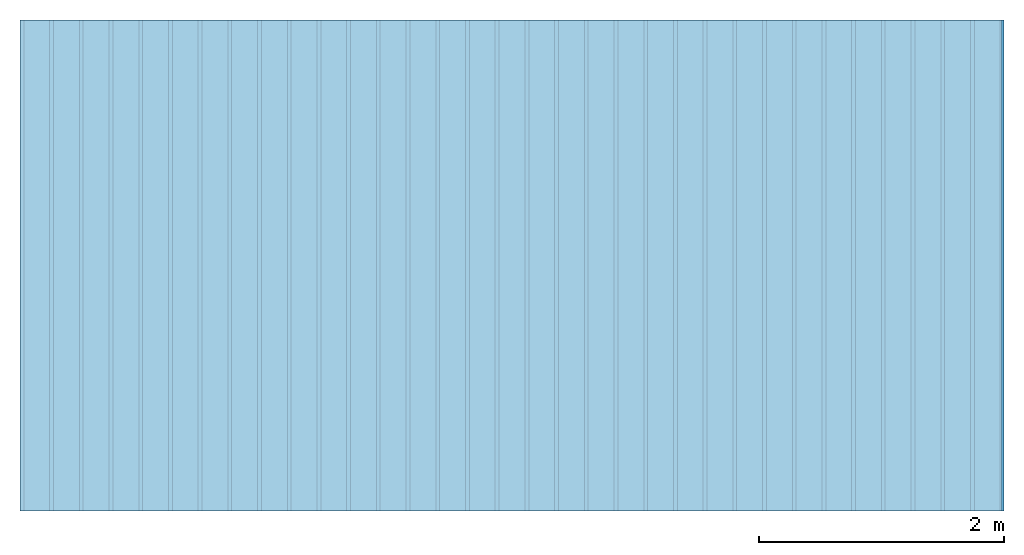
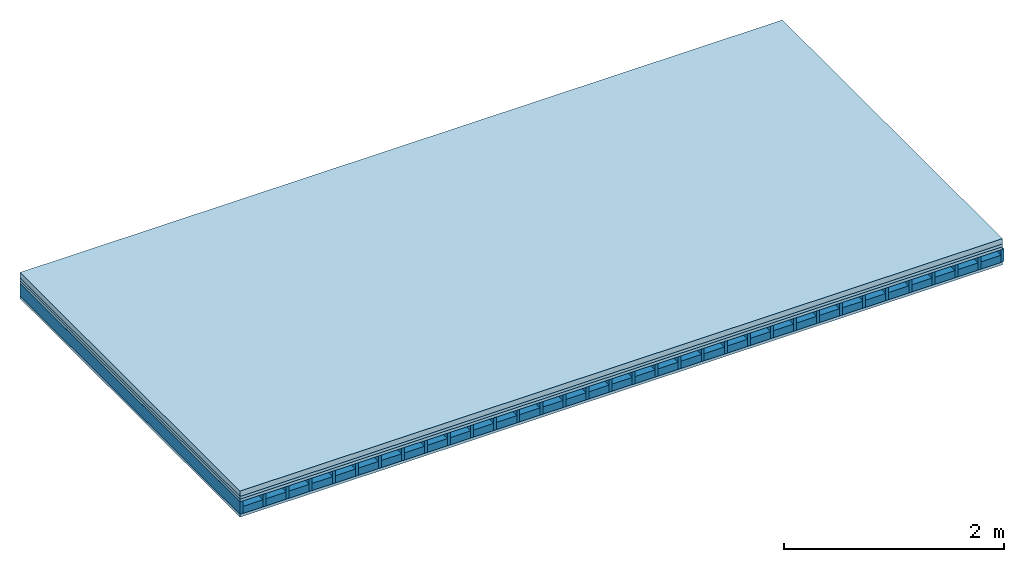
# One storey: 4 plates, 2 members, 1 element without a shape of its own.
"""IFC4 building model written with IfcOpenShell, lengths in metres."""

from ifc_helpers import new_model, si_unit, derived_unit, direction, frame, frame_2d, origin, origin_with_axes, place, context, project, spatial, rectangle, extrude, material, layer, layer_set, type_object, element, aggregate, save


model = new_model("IFC4")

# Units and contexts
plan_context = context("Plan", 3, precision=1e-05, world=origin(), true_north=direction((0.0, 1.0)))
model_context = context("Model", 3, precision=1e-05, world=origin(), true_north=direction((0.0, 1.0)))
ifc_project = project(units=[si_unit("LENGTHUNIT", "METRE"), derived_unit("SOUNDPRESSUREUNIT", [(si_unit("PRESSUREUNIT", "PASCAL", prefix="MICRO"), 0)]), si_unit("ENERGYUNIT", "JOULE", prefix="MEGA"), si_unit("MASSUNIT", "GRAM", prefix="KILO"), derived_unit("THERMALTRANSMITTANCEUNIT", [(si_unit("POWERUNIT", "WATT"), 1), (si_unit("AREAUNIT", "SQUARE_METRE"), -1), (si_unit("THERMODYNAMICTEMPERATUREUNIT", "KELVIN"), -1)]), derived_unit("AREADENSITYUNIT", [(si_unit("MASSUNIT", "GRAM", prefix="KILO"), 1), (si_unit("AREAUNIT", "SQUARE_METRE"), -1)]), derived_unit("USERDEFINED", [(si_unit("ENERGYUNIT", "JOULE", prefix="MEGA"), 1), (si_unit("AREAUNIT", "SQUARE_METRE"), -1)])], contexts=[plan_context, model_context])

# Site, building, storey
site = spatial("IfcSite", under=ifc_project)
building_placement = place(None, origin())
building = spatial("IfcBuilding", under=site, at=building_placement)
storey_placement = place(building_placement, origin())
storey = spatial("IfcBuildingStorey", under=building, at=storey_placement)

# Slab, members, plates
ifc_material_1 = material(Name="Cement screed", Category="04.006")
ifc_layer_1 = layer(ifc_material_1, 0.06, Name="On-material")
ifc_material_2 = material()
ifc_layer_2 = layer(ifc_material_2, 0.03, Name="Impact sound insulation")
ifc_material_3 = material(Name="Element above")
ifc_layer_3 = layer(ifc_material_3, 0.0305, Name="Sub-floor")
ifc_material_4 = material(Name="Rigid")
ifc_layer_4 = layer(ifc_material_4, 0.0, Name="Bond")
ifc_layer_5 = layer(None, 0.139, Name="Supporting structure")
ifc_material_5 = material(Name="Rigid, of the art")
ifc_layer_6 = layer(ifc_material_5, 0.0, Name="Bond")
ifc_material_6 = material(Name="Element below")
ifc_layer_7 = layer(ifc_material_6, 0.0305, Name="Lower layer 1")
ifc_layer_set = layer_set([ifc_layer_1, ifc_layer_2, ifc_layer_3, ifc_layer_4, ifc_layer_5, ifc_layer_6, ifc_layer_7])
slab_type = type_object("IfcSlabType", Name="A2281", PredefinedType="NOTDEFINED", material=ifc_layer_set)
slab_placement = place(None, frame((0.0, 0.0, 0.0), z_axis=(0.0, 0.0, -1.0), x_axis=(1.0, 0.0, 0.0)))
slab = element("IfcSlab", 1, at=slab_placement, inside=storey, type_object=slab_type, material=ifc_layer_set, Name="Slab #1")
ifc_material_7 = material(Name="Floor element EB")
member_1_placement = place(slab_placement, origin())
member_1 = element("IfcMember", 2, at=member_1_placement, material=ifc_material_7, Name="Supporting structure", context=plan_context, shape_type="SweptSolid", body=[
    extrude(rectangle(XDim=0.031, YDim=0.139, at=frame_2d((0.0155, 0.0695), x_axis=(1.0, 0.0))), frame((0.0, 4.0, 0.1205), z_axis=(0.0, -1.0, 0.0), x_axis=(1.0, 0.0, 0.0)), (0.0, 0.0, 1.0), 4.0),
    extrude(rectangle(XDim=0.031, YDim=0.139, at=frame_2d((0.0155, 0.0695), x_axis=(1.0, 0.0))), frame((0.242, 4.0, 0.1205), z_axis=(0.0, -1.0, 0.0), x_axis=(1.0, 0.0, 0.0)), (0.0, 0.0, 1.0), 4.0),
    extrude(rectangle(XDim=0.031, YDim=0.139, at=frame_2d((0.0155, 0.0695), x_axis=(1.0, 0.0))), frame((0.484, 4.0, 0.1205), z_axis=(0.0, -1.0, 0.0), x_axis=(1.0, 0.0, 0.0)), (0.0, 0.0, 1.0), 4.0),
    extrude(rectangle(XDim=0.031, YDim=0.139, at=frame_2d((0.0155, 0.0695), x_axis=(1.0, 0.0))), frame((0.726, 4.0, 0.1205), z_axis=(0.0, -1.0, 0.0), x_axis=(1.0, 0.0, 0.0)), (0.0, 0.0, 1.0), 4.0),
    extrude(rectangle(XDim=0.031, YDim=0.139, at=frame_2d((0.0155, 0.0695), x_axis=(1.0, 0.0))), frame((0.968, 4.0, 0.1205), z_axis=(0.0, -1.0, 0.0), x_axis=(1.0, 0.0, 0.0)), (0.0, 0.0, 1.0), 4.0),
    extrude(rectangle(XDim=0.031, YDim=0.139, at=frame_2d((0.0155, 0.0695), x_axis=(1.0, 0.0))), frame((1.21, 4.0, 0.1205), z_axis=(0.0, -1.0, 0.0), x_axis=(1.0, 0.0, 0.0)), (0.0, 0.0, 1.0), 4.0),
    extrude(rectangle(XDim=0.031, YDim=0.139, at=frame_2d((0.0155, 0.0695), x_axis=(1.0, 0.0))), frame((1.452, 4.0, 0.1205), z_axis=(0.0, -1.0, 0.0), x_axis=(1.0, 0.0, 0.0)), (0.0, 0.0, 1.0), 4.0),
    extrude(rectangle(XDim=0.031, YDim=0.139, at=frame_2d((0.0155, 0.0695), x_axis=(1.0, 0.0))), frame((1.694, 4.0, 0.1205), z_axis=(0.0, -1.0, 0.0), x_axis=(1.0, 0.0, 0.0)), (0.0, 0.0, 1.0), 4.0),
    extrude(rectangle(XDim=0.031, YDim=0.139, at=frame_2d((0.0155, 0.0695), x_axis=(1.0, 0.0))), frame((1.936, 4.0, 0.1205), z_axis=(0.0, -1.0, 0.0), x_axis=(1.0, 0.0, 0.0)), (0.0, 0.0, 1.0), 4.0),
    extrude(rectangle(XDim=0.031, YDim=0.139, at=frame_2d((0.0155, 0.0695), x_axis=(1.0, 0.0))), frame((2.178, 4.0, 0.1205), z_axis=(0.0, -1.0, 0.0), x_axis=(1.0, 0.0, 0.0)), (0.0, 0.0, 1.0), 4.0),
    extrude(rectangle(XDim=0.031, YDim=0.139, at=frame_2d((0.0155, 0.0695), x_axis=(1.0, 0.0))), frame((2.42, 4.0, 0.1205), z_axis=(0.0, -1.0, 0.0), x_axis=(1.0, 0.0, 0.0)), (0.0, 0.0, 1.0), 4.0),
    extrude(rectangle(XDim=0.031, YDim=0.139, at=frame_2d((0.0155, 0.0695), x_axis=(1.0, 0.0))), frame((2.662, 4.0, 0.1205), z_axis=(0.0, -1.0, 0.0), x_axis=(1.0, 0.0, 0.0)), (0.0, 0.0, 1.0), 4.0),
    extrude(rectangle(XDim=0.031, YDim=0.139, at=frame_2d((0.0155, 0.0695), x_axis=(1.0, 0.0))), frame((2.904, 4.0, 0.1205), z_axis=(0.0, -1.0, 0.0), x_axis=(1.0, 0.0, 0.0)), (0.0, 0.0, 1.0), 4.0),
    extrude(rectangle(XDim=0.031, YDim=0.139, at=frame_2d((0.0155, 0.0695), x_axis=(1.0, 0.0))), frame((3.146, 4.0, 0.1205), z_axis=(0.0, -1.0, 0.0), x_axis=(1.0, 0.0, 0.0)), (0.0, 0.0, 1.0), 4.0),
    extrude(rectangle(XDim=0.031, YDim=0.139, at=frame_2d((0.0155, 0.0695), x_axis=(1.0, 0.0))), frame((3.388, 4.0, 0.1205), z_axis=(0.0, -1.0, 0.0), x_axis=(1.0, 0.0, 0.0)), (0.0, 0.0, 1.0), 4.0),
    extrude(rectangle(XDim=0.031, YDim=0.139, at=frame_2d((0.0155, 0.0695), x_axis=(1.0, 0.0))), frame((3.63, 4.0, 0.1205), z_axis=(0.0, -1.0, 0.0), x_axis=(1.0, 0.0, 0.0)), (0.0, 0.0, 1.0), 4.0),
    extrude(rectangle(XDim=0.031, YDim=0.139, at=frame_2d((0.0155, 0.0695), x_axis=(1.0, 0.0))), frame((3.872, 4.0, 0.1205), z_axis=(0.0, -1.0, 0.0), x_axis=(1.0, 0.0, 0.0)), (0.0, 0.0, 1.0), 4.0),
    extrude(rectangle(XDim=0.031, YDim=0.139, at=frame_2d((0.0155, 0.0695), x_axis=(1.0, 0.0))), frame((4.114, 4.0, 0.1205), z_axis=(0.0, -1.0, 0.0), x_axis=(1.0, 0.0, 0.0)), (0.0, 0.0, 1.0), 4.0),
    extrude(rectangle(XDim=0.031, YDim=0.139, at=frame_2d((0.0155, 0.0695), x_axis=(1.0, 0.0))), frame((4.356, 4.0, 0.1205), z_axis=(0.0, -1.0, 0.0), x_axis=(1.0, 0.0, 0.0)), (0.0, 0.0, 1.0), 4.0),
    extrude(rectangle(XDim=0.031, YDim=0.139, at=frame_2d((0.0155, 0.0695), x_axis=(1.0, 0.0))), frame((4.598, 4.0, 0.1205), z_axis=(0.0, -1.0, 0.0), x_axis=(1.0, 0.0, 0.0)), (0.0, 0.0, 1.0), 4.0),
    extrude(rectangle(XDim=0.031, YDim=0.139, at=frame_2d((0.0155, 0.0695), x_axis=(1.0, 0.0))), frame((4.84, 4.0, 0.1205), z_axis=(0.0, -1.0, 0.0), x_axis=(1.0, 0.0, 0.0)), (0.0, 0.0, 1.0), 4.0),
    extrude(rectangle(XDim=0.031, YDim=0.139, at=frame_2d((0.0155, 0.0695), x_axis=(1.0, 0.0))), frame((5.082, 4.0, 0.1205), z_axis=(0.0, -1.0, 0.0), x_axis=(1.0, 0.0, 0.0)), (0.0, 0.0, 1.0), 4.0),
    extrude(rectangle(XDim=0.031, YDim=0.139, at=frame_2d((0.0155, 0.0695), x_axis=(1.0, 0.0))), frame((5.324, 4.0, 0.1205), z_axis=(0.0, -1.0, 0.0), x_axis=(1.0, 0.0, 0.0)), (0.0, 0.0, 1.0), 4.0),
    extrude(rectangle(XDim=0.031, YDim=0.139, at=frame_2d((0.0155, 0.0695), x_axis=(1.0, 0.0))), frame((5.566, 4.0, 0.1205), z_axis=(0.0, -1.0, 0.0), x_axis=(1.0, 0.0, 0.0)), (0.0, 0.0, 1.0), 4.0),
    extrude(rectangle(XDim=0.031, YDim=0.139, at=frame_2d((0.0155, 0.0695), x_axis=(1.0, 0.0))), frame((5.808, 4.0, 0.1205), z_axis=(0.0, -1.0, 0.0), x_axis=(1.0, 0.0, 0.0)), (0.0, 0.0, 1.0), 4.0),
    extrude(rectangle(XDim=0.031, YDim=0.139, at=frame_2d((0.0155, 0.0695), x_axis=(1.0, 0.0))), frame((6.05, 4.0, 0.1205), z_axis=(0.0, -1.0, 0.0), x_axis=(1.0, 0.0, 0.0)), (0.0, 0.0, 1.0), 4.0),
    extrude(rectangle(XDim=0.031, YDim=0.139, at=frame_2d((0.0155, 0.0695), x_axis=(1.0, 0.0))), frame((6.292, 4.0, 0.1205), z_axis=(0.0, -1.0, 0.0), x_axis=(1.0, 0.0, 0.0)), (0.0, 0.0, 1.0), 4.0),
    extrude(rectangle(XDim=0.031, YDim=0.139, at=frame_2d((0.0155, 0.0695), x_axis=(1.0, 0.0))), frame((6.534, 4.0, 0.1205), z_axis=(0.0, -1.0, 0.0), x_axis=(1.0, 0.0, 0.0)), (0.0, 0.0, 1.0), 4.0),
    extrude(rectangle(XDim=0.031, YDim=0.139, at=frame_2d((0.0155, 0.0695), x_axis=(1.0, 0.0))), frame((6.776, 4.0, 0.1205), z_axis=(0.0, -1.0, 0.0), x_axis=(1.0, 0.0, 0.0)), (0.0, 0.0, 1.0), 4.0),
    extrude(rectangle(XDim=0.031, YDim=0.139, at=frame_2d((0.0155, 0.0695), x_axis=(1.0, 0.0))), frame((7.018, 4.0, 0.1205), z_axis=(0.0, -1.0, 0.0), x_axis=(1.0, 0.0, 0.0)), (0.0, 0.0, 1.0), 4.0),
    extrude(rectangle(XDim=0.031, YDim=0.139, at=frame_2d((0.0155, 0.0695), x_axis=(1.0, 0.0))), frame((7.26, 4.0, 0.1205), z_axis=(0.0, -1.0, 0.0), x_axis=(1.0, 0.0, 0.0)), (0.0, 0.0, 1.0), 4.0),
    extrude(rectangle(XDim=0.031, YDim=0.139, at=frame_2d((0.0155, 0.0695), x_axis=(1.0, 0.0))), frame((7.502, 4.0, 0.1205), z_axis=(0.0, -1.0, 0.0), x_axis=(1.0, 0.0, 0.0)), (0.0, 0.0, 1.0), 4.0),
    extrude(rectangle(XDim=0.031, YDim=0.139, at=frame_2d((0.0155, 0.0695), x_axis=(1.0, 0.0))), frame((7.744, 4.0, 0.1205), z_axis=(0.0, -1.0, 0.0), x_axis=(1.0, 0.0, 0.0)), (0.0, 0.0, 1.0), 4.0),
    extrude(rectangle(XDim=0.031, YDim=0.139, at=frame_2d((0.0155, 0.0695), x_axis=(1.0, 0.0))), frame((7.986, 4.0, 0.1205), z_axis=(0.0, -1.0, 0.0), x_axis=(1.0, 0.0, 0.0)), (0.0, 0.0, 1.0), 4.0),
])
ifc_material_8 = material(Name="CCN 2-3mm")
member_2_placement = place(slab_placement, origin())
member_2 = element("IfcMember", 3, at=member_2_placement, material=ifc_material_8, Name="in supporting structure", context=plan_context, shape_type="SweptSolid", body=[
    extrude(rectangle(XDim=0.211, YDim=0.0793, at=frame_2d((0.1055, 0.03965), x_axis=(1.0, 0.0))), frame((0.031, 4.0, 0.1802), z_axis=(0.0, -1.0, 0.0), x_axis=(1.0, 0.0, 0.0)), (0.0, 0.0, 1.0), 4.0),
    extrude(rectangle(XDim=0.211, YDim=0.0793, at=frame_2d((0.1055, 0.03965), x_axis=(1.0, 0.0))), frame((0.273, 4.0, 0.1802), z_axis=(0.0, -1.0, 0.0), x_axis=(1.0, 0.0, 0.0)), (0.0, 0.0, 1.0), 4.0),
    extrude(rectangle(XDim=0.211, YDim=0.0793, at=frame_2d((0.1055, 0.03965), x_axis=(1.0, 0.0))), frame((0.515, 4.0, 0.1802), z_axis=(0.0, -1.0, 0.0), x_axis=(1.0, 0.0, 0.0)), (0.0, 0.0, 1.0), 4.0),
    extrude(rectangle(XDim=0.211, YDim=0.0793, at=frame_2d((0.1055, 0.03965), x_axis=(1.0, 0.0))), frame((0.757, 4.0, 0.1802), z_axis=(0.0, -1.0, 0.0), x_axis=(1.0, 0.0, 0.0)), (0.0, 0.0, 1.0), 4.0),
    extrude(rectangle(XDim=0.211, YDim=0.0793, at=frame_2d((0.1055, 0.03965), x_axis=(1.0, 0.0))), frame((0.999, 4.0, 0.1802), z_axis=(0.0, -1.0, 0.0), x_axis=(1.0, 0.0, 0.0)), (0.0, 0.0, 1.0), 4.0),
    extrude(rectangle(XDim=0.211, YDim=0.0793, at=frame_2d((0.1055, 0.03965), x_axis=(1.0, 0.0))), frame((1.241, 4.0, 0.1802), z_axis=(0.0, -1.0, 0.0), x_axis=(1.0, 0.0, 0.0)), (0.0, 0.0, 1.0), 4.0),
    extrude(rectangle(XDim=0.211, YDim=0.0793, at=frame_2d((0.1055, 0.03965), x_axis=(1.0, 0.0))), frame((1.483, 4.0, 0.1802), z_axis=(0.0, -1.0, 0.0), x_axis=(1.0, 0.0, 0.0)), (0.0, 0.0, 1.0), 4.0),
    extrude(rectangle(XDim=0.211, YDim=0.0793, at=frame_2d((0.1055, 0.03965), x_axis=(1.0, 0.0))), frame((1.725, 4.0, 0.1802), z_axis=(0.0, -1.0, 0.0), x_axis=(1.0, 0.0, 0.0)), (0.0, 0.0, 1.0), 4.0),
    extrude(rectangle(XDim=0.211, YDim=0.0793, at=frame_2d((0.1055, 0.03965), x_axis=(1.0, 0.0))), frame((1.967, 4.0, 0.1802), z_axis=(0.0, -1.0, 0.0), x_axis=(1.0, 0.0, 0.0)), (0.0, 0.0, 1.0), 4.0),
    extrude(rectangle(XDim=0.211, YDim=0.0793, at=frame_2d((0.1055, 0.03965), x_axis=(1.0, 0.0))), frame((2.209, 4.0, 0.1802), z_axis=(0.0, -1.0, 0.0), x_axis=(1.0, 0.0, 0.0)), (0.0, 0.0, 1.0), 4.0),
    extrude(rectangle(XDim=0.211, YDim=0.0793, at=frame_2d((0.1055, 0.03965), x_axis=(1.0, 0.0))), frame((2.451, 4.0, 0.1802), z_axis=(0.0, -1.0, 0.0), x_axis=(1.0, 0.0, 0.0)), (0.0, 0.0, 1.0), 4.0),
    extrude(rectangle(XDim=0.211, YDim=0.0793, at=frame_2d((0.1055, 0.03965), x_axis=(1.0, 0.0))), frame((2.693, 4.0, 0.1802), z_axis=(0.0, -1.0, 0.0), x_axis=(1.0, 0.0, 0.0)), (0.0, 0.0, 1.0), 4.0),
    extrude(rectangle(XDim=0.211, YDim=0.0793, at=frame_2d((0.1055, 0.03965), x_axis=(1.0, 0.0))), frame((2.935, 4.0, 0.1802), z_axis=(0.0, -1.0, 0.0), x_axis=(1.0, 0.0, 0.0)), (0.0, 0.0, 1.0), 4.0),
    extrude(rectangle(XDim=0.211, YDim=0.0793, at=frame_2d((0.1055, 0.03965), x_axis=(1.0, 0.0))), frame((3.177, 4.0, 0.1802), z_axis=(0.0, -1.0, 0.0), x_axis=(1.0, 0.0, 0.0)), (0.0, 0.0, 1.0), 4.0),
    extrude(rectangle(XDim=0.211, YDim=0.0793, at=frame_2d((0.1055, 0.03965), x_axis=(1.0, 0.0))), frame((3.419, 4.0, 0.1802), z_axis=(0.0, -1.0, 0.0), x_axis=(1.0, 0.0, 0.0)), (0.0, 0.0, 1.0), 4.0),
    extrude(rectangle(XDim=0.211, YDim=0.0793, at=frame_2d((0.1055, 0.03965), x_axis=(1.0, 0.0))), frame((3.661, 4.0, 0.1802), z_axis=(0.0, -1.0, 0.0), x_axis=(1.0, 0.0, 0.0)), (0.0, 0.0, 1.0), 4.0),
    extrude(rectangle(XDim=0.211, YDim=0.0793, at=frame_2d((0.1055, 0.03965), x_axis=(1.0, 0.0))), frame((3.903, 4.0, 0.1802), z_axis=(0.0, -1.0, 0.0), x_axis=(1.0, 0.0, 0.0)), (0.0, 0.0, 1.0), 4.0),
    extrude(rectangle(XDim=0.211, YDim=0.0793, at=frame_2d((0.1055, 0.03965), x_axis=(1.0, 0.0))), frame((4.145, 4.0, 0.1802), z_axis=(0.0, -1.0, 0.0), x_axis=(1.0, 0.0, 0.0)), (0.0, 0.0, 1.0), 4.0),
    extrude(rectangle(XDim=0.211, YDim=0.0793, at=frame_2d((0.1055, 0.03965), x_axis=(1.0, 0.0))), frame((4.387, 4.0, 0.1802), z_axis=(0.0, -1.0, 0.0), x_axis=(1.0, 0.0, 0.0)), (0.0, 0.0, 1.0), 4.0),
    extrude(rectangle(XDim=0.211, YDim=0.0793, at=frame_2d((0.1055, 0.03965), x_axis=(1.0, 0.0))), frame((4.629, 4.0, 0.1802), z_axis=(0.0, -1.0, 0.0), x_axis=(1.0, 0.0, 0.0)), (0.0, 0.0, 1.0), 4.0),
    extrude(rectangle(XDim=0.211, YDim=0.0793, at=frame_2d((0.1055, 0.03965), x_axis=(1.0, 0.0))), frame((4.871, 4.0, 0.1802), z_axis=(0.0, -1.0, 0.0), x_axis=(1.0, 0.0, 0.0)), (0.0, 0.0, 1.0), 4.0),
    extrude(rectangle(XDim=0.211, YDim=0.0793, at=frame_2d((0.1055, 0.03965), x_axis=(1.0, 0.0))), frame((5.113, 4.0, 0.1802), z_axis=(0.0, -1.0, 0.0), x_axis=(1.0, 0.0, 0.0)), (0.0, 0.0, 1.0), 4.0),
    extrude(rectangle(XDim=0.211, YDim=0.0793, at=frame_2d((0.1055, 0.03965), x_axis=(1.0, 0.0))), frame((5.355, 4.0, 0.1802), z_axis=(0.0, -1.0, 0.0), x_axis=(1.0, 0.0, 0.0)), (0.0, 0.0, 1.0), 4.0),
    extrude(rectangle(XDim=0.211, YDim=0.0793, at=frame_2d((0.1055, 0.03965), x_axis=(1.0, 0.0))), frame((5.597, 4.0, 0.1802), z_axis=(0.0, -1.0, 0.0), x_axis=(1.0, 0.0, 0.0)), (0.0, 0.0, 1.0), 4.0),
    extrude(rectangle(XDim=0.211, YDim=0.0793, at=frame_2d((0.1055, 0.03965), x_axis=(1.0, 0.0))), frame((5.839, 4.0, 0.1802), z_axis=(0.0, -1.0, 0.0), x_axis=(1.0, 0.0, 0.0)), (0.0, 0.0, 1.0), 4.0),
    extrude(rectangle(XDim=0.211, YDim=0.0793, at=frame_2d((0.1055, 0.03965), x_axis=(1.0, 0.0))), frame((6.081, 4.0, 0.1802), z_axis=(0.0, -1.0, 0.0), x_axis=(1.0, 0.0, 0.0)), (0.0, 0.0, 1.0), 4.0),
    extrude(rectangle(XDim=0.211, YDim=0.0793, at=frame_2d((0.1055, 0.03965), x_axis=(1.0, 0.0))), frame((6.323, 4.0, 0.1802), z_axis=(0.0, -1.0, 0.0), x_axis=(1.0, 0.0, 0.0)), (0.0, 0.0, 1.0), 4.0),
    extrude(rectangle(XDim=0.211, YDim=0.0793, at=frame_2d((0.1055, 0.03965), x_axis=(1.0, 0.0))), frame((6.565, 4.0, 0.1802), z_axis=(0.0, -1.0, 0.0), x_axis=(1.0, 0.0, 0.0)), (0.0, 0.0, 1.0), 4.0),
    extrude(rectangle(XDim=0.211, YDim=0.0793, at=frame_2d((0.1055, 0.03965), x_axis=(1.0, 0.0))), frame((6.807, 4.0, 0.1802), z_axis=(0.0, -1.0, 0.0), x_axis=(1.0, 0.0, 0.0)), (0.0, 0.0, 1.0), 4.0),
    extrude(rectangle(XDim=0.211, YDim=0.0793, at=frame_2d((0.1055, 0.03965), x_axis=(1.0, 0.0))), frame((7.049, 4.0, 0.1802), z_axis=(0.0, -1.0, 0.0), x_axis=(1.0, 0.0, 0.0)), (0.0, 0.0, 1.0), 4.0),
    extrude(rectangle(XDim=0.211, YDim=0.0793, at=frame_2d((0.1055, 0.03965), x_axis=(1.0, 0.0))), frame((7.291, 4.0, 0.1802), z_axis=(0.0, -1.0, 0.0), x_axis=(1.0, 0.0, 0.0)), (0.0, 0.0, 1.0), 4.0),
    extrude(rectangle(XDim=0.211, YDim=0.0793, at=frame_2d((0.1055, 0.03965), x_axis=(1.0, 0.0))), frame((7.533, 4.0, 0.1802), z_axis=(0.0, -1.0, 0.0), x_axis=(1.0, 0.0, 0.0)), (0.0, 0.0, 1.0), 4.0),
    extrude(rectangle(XDim=0.211, YDim=0.0793, at=frame_2d((0.1055, 0.03965), x_axis=(1.0, 0.0))), frame((7.775, 4.0, 0.1802), z_axis=(0.0, -1.0, 0.0), x_axis=(1.0, 0.0, 0.0)), (0.0, 0.0, 1.0), 4.0),
])
plate_1_placement = place(slab_placement, origin())
plate_1 = element("IfcPlate", 4, at=plate_1_placement, material=ifc_material_1, Name="On-material", context=plan_context, shape_type="SweptSolid", body=[
    extrude(rectangle(XDim=8.0, YDim=4.0, at=frame_2d((4.0, 2.0), x_axis=(1.0, 0.0))), origin_with_axes(), (0.0, 0.0, 1.0), 0.06),
])
plate_2_placement = place(slab_placement, origin())
plate_2 = element("IfcPlate", 5, at=plate_2_placement, material=ifc_material_2, Name="Impact sound insulation", context=plan_context, shape_type="SweptSolid", body=[
    extrude(rectangle(XDim=8.0, YDim=4.0, at=frame_2d((4.0, 2.0), x_axis=(1.0, 0.0))), frame((0.0, 0.0, 0.06), z_axis=(0.0, 0.0, 1.0), x_axis=(1.0, 0.0, 0.0)), (0.0, 0.0, 1.0), 0.03),
])
plate_3_placement = place(slab_placement, origin())
plate_3 = element("IfcPlate", 6, at=plate_3_placement, material=ifc_material_3, Name="Sub-floor", context=plan_context, shape_type="SweptSolid", body=[
    extrude(rectangle(XDim=8.0, YDim=4.0, at=frame_2d((4.0, 2.0), x_axis=(1.0, 0.0))), frame((0.0, 0.0, 0.09), z_axis=(0.0, 0.0, 1.0), x_axis=(1.0, 0.0, 0.0)), (0.0, 0.0, 1.0), 0.0305),
])
plate_4_placement = place(slab_placement, origin())
plate_4 = element("IfcPlate", 7, at=plate_4_placement, material=ifc_material_6, Name="Lower layer 1", context=plan_context, shape_type="SweptSolid", body=[
    extrude(rectangle(XDim=8.0, YDim=4.0, at=frame_2d((4.0, 2.0), x_axis=(1.0, 0.0))), frame((0.0, 0.0, 0.2595), z_axis=(0.0, 0.0, 1.0), x_axis=(1.0, 0.0, 0.0)), (0.0, 0.0, 1.0), 0.0305),
])
aggregate(slab, [plate_1, plate_2, plate_3, member_1, member_2, plate_4])

save(model, "model.ifc")
